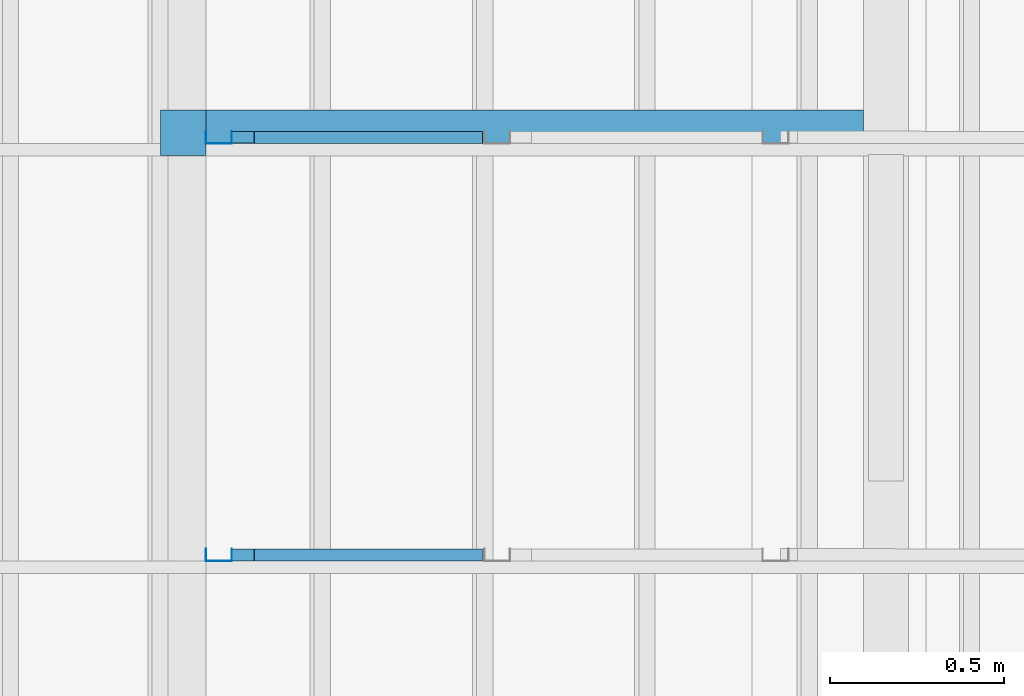
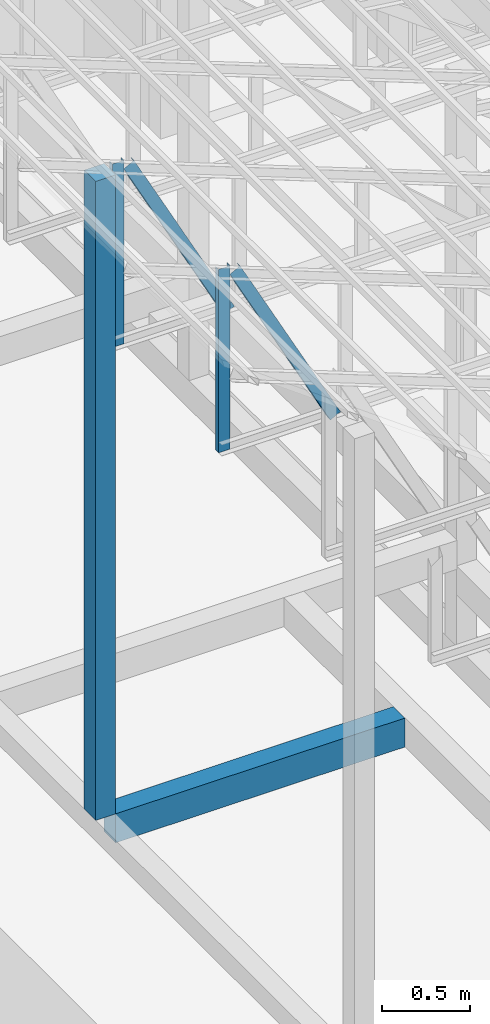
# One storey, part 6 of 22: 4 members, 2 beams, 1 element without a shape of its own.
"""IFC4 building model written with IfcOpenShell, lengths in millimetres."""

from ifc_helpers import new_model, entity, si_unit, converted_unit, frame, origin_with_axes, origin_2d_with_axis, place, context, subcontext, project, spatial, indexed_curve, rectangle, c_section, outline, extrude, material, material_profile, profile_set, profile_usage, type_object, element, aggregate, save


model = new_model("IFC4")

# Units and contexts
model_context = context("Model", 3, precision=1e-05, world=origin_with_axes())
plan_context = context("Plan", 2, precision=1e-05, world=origin_2d_with_axis())
body_context = subcontext(model_context, "Body", "Model", "MODEL_VIEW")
ifc_project = project(units=[si_unit("VOLUMEUNIT", "CUBIC_METRE"), si_unit("LENGTHUNIT", "METRE", prefix="MILLI"), si_unit("AREAUNIT", "SQUARE_METRE"), converted_unit("PLANEANGLEUNIT", "degree", entity("IfcReal", 0.0174532925199433), si_unit("PLANEANGLEUNIT", "RADIAN"), dimensions=[0, 0, 0, 0, 0, 0, 0])], contexts=[model_context, plan_context])

# Site, building, storey
site_placement = place(None, origin_with_axes())
site = spatial("IfcSite", under=ifc_project, at=site_placement)
building_placement = place(site_placement, origin_with_axes())
building = spatial("IfcBuilding", under=site, at=building_placement, Name="2")
storey_placement = place(building_placement, frame((0.0, 0.0, 200.000002980232), z_axis=(0.0, 0.0, 1.0), x_axis=(1.0, 0.0, 0.0)))
storey = spatial("IfcBuildingStorey", under=building, at=storey_placement)

# Beams
ifc_material_1 = material(Name="Concrete")
ifc_material_profile_1 = material_profile(ifc_material_1, outline(indexed_curve([(-65.0, 99.9999923706055), (65.0, 99.9999923706055), (65.0, -99.9999923706055), (-65.0, -99.9999923706055), (-65.0, 99.9999923706055)])))
ifc_profile_set_1 = profile_set([ifc_material_profile_1])
ifc_profile_usage_1 = profile_usage(ifc_profile_set_1, cardinal=2)
beam_type_1 = type_object("IfcBeamType", PredefinedType="BEAM", material=ifc_profile_set_1)
beam_1_placement = place(storey_placement, frame((-7084.99765396118, 9930.00030517578, 535.000070929528), z_axis=(0.999999999999932, -1.9470714107682e-07, 3.13916473260157e-07), x_axis=(1.94707183709391e-07, 0.99999999999997, -1.49011611938472e-07)))
element("IfcBeam", 1, at=beam_1_placement, inside=storey, type_object=beam_type_1, material=ifc_profile_usage_1, Name="Beam", PredefinedType="BEAM", context=body_context, shape_type="SweptSolid", body=[
    extrude(outline(indexed_curve([(-65.0, 99.9999923706055), (65.0, 99.9999923706055), (65.0, -99.9999923706055), (-65.0, -99.9999923706055), (-65.0, 99.9999923706055)])), frame((0.0, 99.9999923706055, 0.0), z_axis=(0.0, 0.0, 1.0), x_axis=(1.0, 0.0, 0.0)), (0.0, 0.0, 1.0), 1890.00225056922),
])
ifc_material_profile_2 = material_profile(ifc_material_1, rectangle(XDim=130.000015258789, YDim=130.000015258789, kind="CURVE"))
ifc_profile_set_2 = profile_set([ifc_material_profile_2])
ifc_profile_usage_2 = profile_usage(ifc_profile_set_2, cardinal=5)
beam_type_2 = type_object("IfcBeamType", PredefinedType="BEAM", material=ifc_profile_set_2)
beam_2_placement = place(storey_placement, frame((-7150.00057220459, 9930.00030517578, 735.002025961876), z_axis=(0.0, 0.0, 1.0), x_axis=(1.0, 0.0, 0.0)))
element("IfcBeam", 2, at=beam_2_placement, inside=storey, type_object=beam_type_2, material=ifc_profile_usage_2, Name="Column", PredefinedType="BEAM", context=body_context, shape_type="SweptSolid", body=[
    extrude(rectangle(XDim=130.000015258789, YDim=130.000015258789, kind="CURVE"), origin_with_axes(), (0.0, 0.0, 1.0), 4411.20772417435),
])

# Assembly, members
assembly_placement = place(storey_placement, frame((-3938.51041793823, 5099.00283813477, 3935.3459328413), z_axis=(0.0, 0.0, 1.0), x_axis=(1.0, 0.0, 0.0)))
assembly = element("IfcElementAssembly", 3, at=assembly_placement, inside=storey, Name="2")
ifc_material_2 = material(Name="STEEL")
ifc_material_profile_3 = material_profile(ifc_material_2, c_section(Depth=75.0, Width=35.0, WallThickness=1.0, Girth=1.0, kind="CURVE"))
ifc_profile_set_3 = profile_set([ifc_material_profile_3])
ifc_profile_usage_3 = profile_usage(ifc_profile_set_3, cardinal=1)
member_type = type_object("IfcMemberType", Name="C75", PredefinedType="CHORD", material=ifc_profile_set_3)
member_1_placement = place(assembly_placement, frame((-3146.51107788086, 3634.9983215332, 1265.15865325928), z_axis=(-8.74227410463377e-08, -1.50995830949794e-07, -0.999999999999985), x_axis=(-3.13916473260159e-07, 0.999999999999939, -1.50995802528077e-07)))
member_1 = element("IfcMember", 4, at=member_1_placement, type_object=member_type, material=ifc_profile_usage_3, Name="Member", context=body_context, shape_type="SweptSolid", body=[
    extrude(c_section(Depth=75.0, Width=35.0, WallThickness=1.0, Girth=1.0, kind="CURVE"), frame((-17.5, 37.5, 0.0), z_axis=(0.0, 0.0, 1.0), x_axis=(1.0, 0.0, 0.0)), (0.0, 0.0, 1.0), 1266.51238309135),
])
ifc_profile_usage_4 = profile_usage(ifc_profile_set_3, cardinal=9)
member_2_placement = place(assembly_placement, frame((-3006.42156600952, 3599.99847412109, 1241.45650863647), z_axis=(0.468464370953309, -3.43728484817469e-07, -0.88348238983423), x_axis=(6.7154434191237e-07, 0.999999999999774, -3.29761675743537e-08)))
member_2 = element("IfcMember", 5, at=member_2_placement, type_object=member_type, material=ifc_profile_usage_4, Name="Member", context=body_context, shape_type="SweptSolid", body=[
    extrude(c_section(Depth=75.0, Width=35.0, WallThickness=1.0, Girth=1.0, kind="CURVE"), frame((17.5, -37.5, 0.0), z_axis=(0.0, 0.0, 1.0), x_axis=(1.0, 0.0, 0.0)), (0.0, 0.0, 1.0), 1399.63894386164),
])
ifc_profile_usage_5 = profile_usage(ifc_profile_set_3, cardinal=1)
member_3_placement = place(assembly_placement, frame((-3146.51107788086, 4834.99813079834, 1265.15865325928), z_axis=(-8.74227410463377e-08, -1.50995830949794e-07, -0.999999999999985), x_axis=(-3.13916473260159e-07, 0.999999999999939, -1.50995802528077e-07)))
member_3 = element("IfcMember", 6, at=member_3_placement, type_object=member_type, material=ifc_profile_usage_5, Name="Member", context=body_context, shape_type="SweptSolid", body=[
    extrude(c_section(Depth=75.0, Width=35.0, WallThickness=1.0, Girth=1.0, kind="CURVE"), frame((-17.5, 37.5, 0.0), z_axis=(0.0, 0.0, 1.0), x_axis=(1.0, 0.0, 0.0)), (0.0, 0.0, 1.0), 1266.51238309135),
])
ifc_profile_usage_6 = profile_usage(ifc_profile_set_3, cardinal=9)
member_4_placement = place(assembly_placement, frame((-3006.42156600952, 4799.99828338623, 1241.45650863647), z_axis=(0.468464370953309, -3.43728484817469e-07, -0.88348238983423), x_axis=(6.7154434191237e-07, 0.999999999999774, -3.29761675743537e-08)))
member_4 = element("IfcMember", 7, at=member_4_placement, type_object=member_type, material=ifc_profile_usage_6, Name="Member", context=body_context, shape_type="SweptSolid", body=[
    extrude(c_section(Depth=75.0, Width=35.0, WallThickness=1.0, Girth=1.0, kind="CURVE"), frame((17.5, -37.5, 0.0), z_axis=(0.0, 0.0, 1.0), x_axis=(1.0, 0.0, 0.0)), (0.0, 0.0, 1.0), 1399.63894386164),
])
aggregate(assembly, [member_1, member_2, member_3, member_4])

save(model, "model.ifc")
